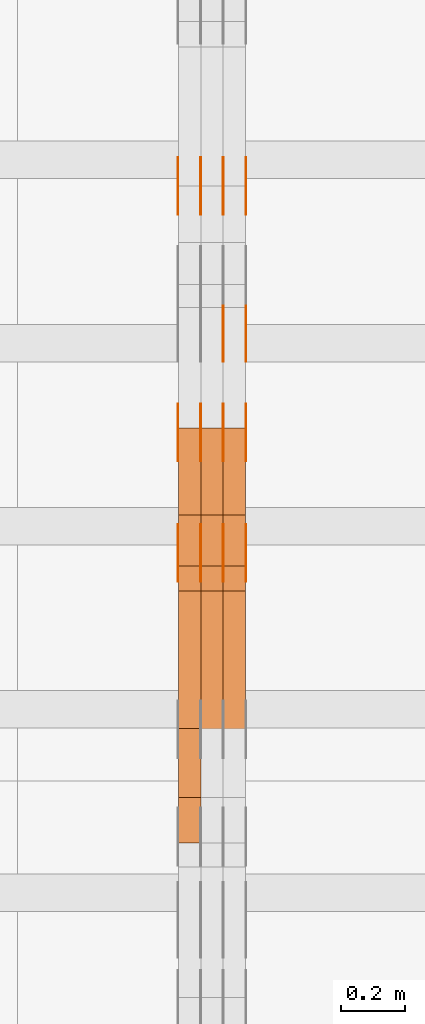
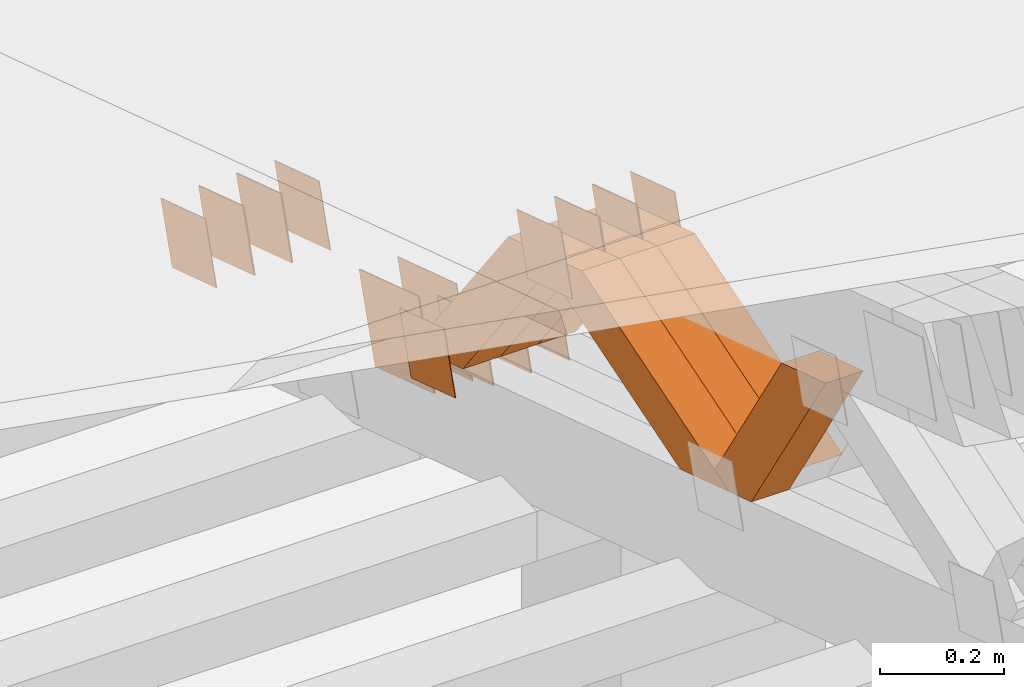
# One storey, part 333 of 385: 28 proxies.
"""IFC2X3 building model written with IfcOpenShell, lengths in millimetres."""

from ifc_helpers import new_model, entity, si_unit, converted_unit, derived_unit, direction, frame, origin, place, context, subcontext, project, spatial, polyline, outline, extrude, source, transform, mapped, material, type_object, type_shapes, element, save


model = new_model("IFC2X3")

# Units and contexts
model_context = context("Model", 3, precision=0.01, world=origin(), true_north=direction((6.12303176911189e-17, 1.0)))
body_context = subcontext(model_context, "Body", "Model", "MODEL_VIEW")
ifc_project = project(units=[si_unit("LENGTHUNIT", "METRE", prefix="MILLI"), si_unit("AREAUNIT", "SQUARE_METRE"), si_unit("VOLUMEUNIT", "CUBIC_METRE"), converted_unit("PLANEANGLEUNIT", "DEGREE", entity("IfcRatioMeasure", 0.0174532925199433), si_unit("PLANEANGLEUNIT", "RADIAN"), dimensions=[0, 0, 0, 0, 0, 0, 0]), si_unit("MASSUNIT", "GRAM", prefix="KILO"), derived_unit("MASSDENSITYUNIT", [(si_unit("MASSUNIT", "GRAM", prefix="KILO"), 1), (si_unit("LENGTHUNIT", "METRE"), -3)]), si_unit("TIMEUNIT", "SECOND"), si_unit("FREQUENCYUNIT", "HERTZ"), si_unit("THERMODYNAMICTEMPERATUREUNIT", "DEGREE_CELSIUS"), derived_unit("THERMALTRANSMITTANCEUNIT", [(si_unit("MASSUNIT", "GRAM", prefix="KILO"), 1), (si_unit("THERMODYNAMICTEMPERATUREUNIT", "KELVIN"), -1), (si_unit("TIMEUNIT", "SECOND"), -3)]), derived_unit("VOLUMETRICFLOWRATEUNIT", [(si_unit("LENGTHUNIT", "METRE"), 3), (si_unit("TIMEUNIT", "SECOND"), -1)]), si_unit("ELECTRICCURRENTUNIT", "AMPERE"), si_unit("ELECTRICVOLTAGEUNIT", "VOLT"), si_unit("POWERUNIT", "WATT"), si_unit("FORCEUNIT", "NEWTON", prefix="KILO"), si_unit("ILLUMINANCEUNIT", "LUX"), si_unit("LUMINOUSFLUXUNIT", "LUMEN"), si_unit("LUMINOUSINTENSITYUNIT", "CANDELA"), derived_unit("USERDEFINED", [(si_unit("MASSUNIT", "GRAM", prefix="KILO"), -1), (si_unit("LENGTHUNIT", "METRE"), -2), (si_unit("TIMEUNIT", "SECOND"), 3), (si_unit("LUMINOUSFLUXUNIT", "LUMEN"), 1)]), derived_unit("LINEARVELOCITYUNIT", [(si_unit("LENGTHUNIT", "METRE"), 1), (si_unit("TIMEUNIT", "SECOND"), -1)]), si_unit("PRESSUREUNIT", "PASCAL"), derived_unit("USERDEFINED", [(si_unit("LENGTHUNIT", "METRE"), -2), (si_unit("MASSUNIT", "GRAM", prefix="KILO"), 1), (si_unit("TIMEUNIT", "SECOND"), -2)])], contexts=[model_context])

# Site, building, storey
site_placement = place(None, origin())
site = spatial("IfcSite", under=ifc_project, at=site_placement, CompositionType="ELEMENT")
building_placement = place(site_placement, origin())
building = spatial("IfcBuilding", under=site, at=building_placement, CompositionType="ELEMENT")
storey_placement = place(building_placement, origin())
storey = spatial("IfcBuildingStorey", under=building, at=storey_placement, Name="Default", CompositionType="ELEMENT", Elevation=0.0)

# Proxies
ifc_material_1 = material(Name="IfcSurfaceStyle #412996")
building_element_proxy_type_1 = type_object("IfcBuildingElementProxyType", PredefinedType="NOTDEFINED", material=ifc_material_1)
shared_shape_1 = source(origin(), body_context, "Body", "SweptSolid", [
    extrude(outline(polyline([(-74.9998794200123, -59.999984515643), (74.9998565677174, -59.999984515643), (74.9998794200123, 59.999984515643), (-74.9998565677174, 59.999984515643), (-74.9998794200123, -59.999984515643)])), frame((75.0000769557496, 60.0000596852268, 0.0), z_axis=(0.0, 0.0, 1.0), x_axis=(-1.0, 0.0, 0.0)), (0.0, 0.0, 1.0), 1.3),
])
type_shapes(building_element_proxy_type_1, [shared_shape_1])
proxy_1_placement = place(building_placement, frame((33386.3, 22649.3668870864, 1282.62115477841), z_axis=(-1.0, 0.0, 0.0), x_axis=(0.0, -0.951056516295124, 0.309016994375039)))
element("IfcBuildingElementProxy", 1, at=proxy_1_placement, inside=storey, type_object=building_element_proxy_type_1, material=ifc_material_1, context=body_context, shape_type="MappedRepresentation", body=[
    mapped(shared_shape_1, transform((0.0, 0.0, 0.0), scale=1.0)),
])
ifc_material_2 = material(Name="IfcSurfaceStyle #412939")
building_element_proxy_type_2 = type_object("IfcBuildingElementProxyType", PredefinedType="NOTDEFINED", material=ifc_material_2)
shared_shape_2 = source(origin(), body_context, "Body", "SweptSolid", [
    extrude(outline(polyline([(-74.9998794200123, -59.999984515643), (74.9998565677174, -59.999984515643), (74.9998794200123, 59.999984515643), (-74.9998565677174, 59.999984515643), (-74.9998794200123, -59.999984515643)])), frame((75.0000769557496, 60.0000596852268, 0.0), z_axis=(0.0, 0.0, 1.0), x_axis=(-1.0, 0.0, 0.0)), (0.0, 0.0, 1.0), 1.3),
])
type_shapes(building_element_proxy_type_2, [shared_shape_2])
proxy_2_placement = place(building_placement, frame((33315.0, 22649.3668870864, 1282.62115477841), z_axis=(-1.0, 0.0, 0.0), x_axis=(0.0, -0.951056516295124, 0.309016994375039)))
element("IfcBuildingElementProxy", 2, at=proxy_2_placement, inside=storey, type_object=building_element_proxy_type_2, material=ifc_material_2, context=body_context, shape_type="MappedRepresentation", body=[
    mapped(shared_shape_2, transform((0.0, 0.0, 0.0), scale=1.0)),
])
ifc_material_3 = material(Name="IfcSurfaceStyle #412882")
building_element_proxy_type_3 = type_object("IfcBuildingElementProxyType", PredefinedType="NOTDEFINED", material=ifc_material_3)
shared_shape_3 = source(origin(), body_context, "Body", "SweptSolid", [
    extrude(outline(polyline([(-74.9998794200123, -59.999984515643), (74.9998565677174, -59.999984515643), (74.9998794200123, 59.999984515643), (-74.9998565677174, 59.999984515643), (-74.9998794200123, -59.999984515643)])), frame((75.0000769557496, 60.0000596852268, 0.0), z_axis=(0.0, 0.0, 1.0), x_axis=(-1.0, 0.0, 0.0)), (0.0, 0.0, 1.0), 1.3),
])
type_shapes(building_element_proxy_type_3, [shared_shape_3])
proxy_3_placement = place(building_placement, frame((33316.3, 22649.3668870864, 1282.62115477841), z_axis=(-1.0, 0.0, 0.0), x_axis=(0.0, -0.951056516295124, 0.309016994375039)))
element("IfcBuildingElementProxy", 3, at=proxy_3_placement, inside=storey, type_object=building_element_proxy_type_3, material=ifc_material_3, context=body_context, shape_type="MappedRepresentation", body=[
    mapped(shared_shape_3, transform((0.0, 0.0, 0.0), scale=1.0)),
])
ifc_material_4 = material(Name="IfcSurfaceStyle #412825")
building_element_proxy_type_4 = type_object("IfcBuildingElementProxyType", PredefinedType="NOTDEFINED", material=ifc_material_4)
shared_shape_4 = source(origin(), body_context, "Body", "SweptSolid", [
    extrude(outline(polyline([(-74.9998794200123, -59.999984515643), (74.9998565677174, -59.999984515643), (74.9998794200123, 59.999984515643), (-74.9998565677174, 59.999984515643), (-74.9998794200123, -59.999984515643)])), frame((75.0000769557496, 60.0000596852268, 0.0), z_axis=(0.0, 0.0, 1.0), x_axis=(-1.0, 0.0, 0.0)), (0.0, 0.0, 1.0), 1.29999999999999),
])
type_shapes(building_element_proxy_type_4, [shared_shape_4])
proxy_4_placement = place(building_placement, frame((33245.0, 22649.3668870864, 1282.62115477841), z_axis=(-1.0, 0.0, 0.0), x_axis=(0.0, -0.951056516295124, 0.309016994375039)))
element("IfcBuildingElementProxy", 4, at=proxy_4_placement, inside=storey, type_object=building_element_proxy_type_4, material=ifc_material_4, context=body_context, shape_type="MappedRepresentation", body=[
    mapped(shared_shape_4, transform((0.0, 0.0, 0.0), scale=1.0)),
])
ifc_material_5 = material(Name="IfcSurfaceStyle #412768")
building_element_proxy_type_5 = type_object("IfcBuildingElementProxyType", PredefinedType="NOTDEFINED", material=ifc_material_5)
shared_shape_5 = source(origin(), body_context, "Body", "SweptSolid", [
    extrude(outline(polyline([(-74.9998794200123, -59.999984515643), (74.9998565677174, -59.999984515643), (74.9998794200123, 59.999984515643), (-74.9998565677174, 59.999984515643), (-74.9998794200123, -59.999984515643)])), frame((75.0000769557496, 60.0000596852268, 0.0), z_axis=(0.0, 0.0, 1.0), x_axis=(-1.0, 0.0, 0.0)), (0.0, 0.0, 1.0), 1.29999999999999),
])
type_shapes(building_element_proxy_type_5, [shared_shape_5])
proxy_5_placement = place(building_placement, frame((33246.3, 22649.3668870864, 1282.62115477841), z_axis=(-1.0, 0.0, 0.0), x_axis=(0.0, -0.951056516295124, 0.309016994375039)))
element("IfcBuildingElementProxy", 5, at=proxy_5_placement, inside=storey, type_object=building_element_proxy_type_5, material=ifc_material_5, context=body_context, shape_type="MappedRepresentation", body=[
    mapped(shared_shape_5, transform((0.0, 0.0, 0.0), scale=1.0)),
])
ifc_material_6 = material(Name="IfcSurfaceStyle #412711")
building_element_proxy_type_6 = type_object("IfcBuildingElementProxyType", PredefinedType="NOTDEFINED", material=ifc_material_6)
shared_shape_6 = source(origin(), body_context, "Body", "SweptSolid", [
    extrude(outline(polyline([(-74.9998794200123, -59.999984515643), (74.9998565677174, -59.999984515643), (74.9998794200123, 59.999984515643), (-74.9998565677174, 59.999984515643), (-74.9998794200123, -59.999984515643)])), frame((75.0000769557496, 60.0000596852268, 0.0), z_axis=(0.0, 0.0, 1.0), x_axis=(-1.0, 0.0, 0.0)), (0.0, 0.0, 1.0), 1.29999999999999),
])
type_shapes(building_element_proxy_type_6, [shared_shape_6])
proxy_6_placement = place(building_placement, frame((33175.0, 22649.3668870864, 1282.62115477841), z_axis=(-1.0, 0.0, 0.0), x_axis=(0.0, -0.951056516295124, 0.309016994375039)))
element("IfcBuildingElementProxy", 6, at=proxy_6_placement, inside=storey, type_object=building_element_proxy_type_6, material=ifc_material_6, context=body_context, shape_type="MappedRepresentation", body=[
    mapped(shared_shape_6, transform((0.0, 0.0, 0.0), scale=1.0)),
])
ifc_material_7 = material(Name="IfcSurfaceStyle #412312")
building_element_proxy_type_7 = type_object("IfcBuildingElementProxyType", PredefinedType="NOTDEFINED", material=ifc_material_7)
shared_shape_7 = source(origin(), body_context, "Body", "SweptSolid", [
    extrude(outline(polyline([(-99.9999579276585, -84.0000593595837), (100.000141865112, -84.0000593595837), (99.9999579276589, 84.0000593595837), (-100.000141865112, 84.0000593595837), (-99.9999579276585, -84.0000593595837)])), frame((100.000141865112, 84.0000593595837, 0.0), z_axis=(0.0, 0.0, 1.0), x_axis=(-1.0, 0.0, 0.0)), (0.0, 0.0, 1.0), 1.3),
])
type_shapes(building_element_proxy_type_7, [shared_shape_7])
proxy_7_placement = place(building_placement, frame((33386.3, 22239.7296395088, 1287.96775368191), z_axis=(-1.0, 0.0, 0.0), x_axis=(0.0, -0.951056516295124, 0.309016994375039)))
element("IfcBuildingElementProxy", 7, at=proxy_7_placement, inside=storey, type_object=building_element_proxy_type_7, material=ifc_material_7, context=body_context, shape_type="MappedRepresentation", body=[
    mapped(shared_shape_7, transform((0.0, 0.0, 0.0), scale=1.0)),
])
ifc_material_8 = material(Name="IfcSurfaceStyle #412255")
building_element_proxy_type_8 = type_object("IfcBuildingElementProxyType", PredefinedType="NOTDEFINED", material=ifc_material_8)
shared_shape_8 = source(origin(), body_context, "Body", "SweptSolid", [
    extrude(outline(polyline([(-99.9999579276585, -84.0000593595837), (100.000141865112, -84.0000593595837), (99.9999579276589, 84.0000593595837), (-100.000141865112, 84.0000593595837), (-99.9999579276585, -84.0000593595837)])), frame((100.000141865112, 84.0000593595837, 0.0), z_axis=(0.0, 0.0, 1.0), x_axis=(-1.0, 0.0, 0.0)), (0.0, 0.0, 1.0), 1.3),
])
type_shapes(building_element_proxy_type_8, [shared_shape_8])
proxy_8_placement = place(building_placement, frame((33315.0, 22239.7296395088, 1287.96775368191), z_axis=(-1.0, 0.0, 0.0), x_axis=(0.0, -0.951056516295124, 0.309016994375039)))
element("IfcBuildingElementProxy", 8, at=proxy_8_placement, inside=storey, type_object=building_element_proxy_type_8, material=ifc_material_8, context=body_context, shape_type="MappedRepresentation", body=[
    mapped(shared_shape_8, transform((0.0, 0.0, 0.0), scale=1.0)),
])
ifc_material_9 = material(Name="IfcSurfaceStyle #412198")
building_element_proxy_type_9 = type_object("IfcBuildingElementProxyType", PredefinedType="NOTDEFINED", material=ifc_material_9)
shared_shape_9 = source(origin(), body_context, "Body", "SweptSolid", [
    extrude(outline(polyline([(-99.9999579276585, -84.0000593595837), (100.000141865112, -84.0000593595837), (99.9999579276589, 84.0000593595837), (-100.000141865112, 84.0000593595837), (-99.9999579276585, -84.0000593595837)])), frame((100.000141865112, 84.0000593595837, 0.0), z_axis=(0.0, 0.0, 1.0), x_axis=(-1.0, 0.0, 0.0)), (0.0, 0.0, 1.0), 1.3),
])
type_shapes(building_element_proxy_type_9, [shared_shape_9])
proxy_9_placement = place(building_placement, frame((33316.3, 22239.7296395088, 1287.96775368191), z_axis=(-1.0, 0.0, 0.0), x_axis=(0.0, -0.951056516295124, 0.309016994375039)))
element("IfcBuildingElementProxy", 9, at=proxy_9_placement, inside=storey, type_object=building_element_proxy_type_9, material=ifc_material_9, context=body_context, shape_type="MappedRepresentation", body=[
    mapped(shared_shape_9, transform((0.0, 0.0, 0.0), scale=1.0)),
])
ifc_material_10 = material(Name="IfcSurfaceStyle #409918")
building_element_proxy_type_10 = type_object("IfcBuildingElementProxyType", PredefinedType="NOTDEFINED", material=ifc_material_10)
shared_shape_10 = source(origin(), body_context, "Body", "SweptSolid", [
    extrude(outline(polyline([(-75.0001116115454, -60.0000599592451), (75.0000887592496, -60.0000599592451), (75.0001116115454, 60.0000599592451), (-75.0000887592496, 60.0000599592451), (-75.0001116115454, -60.0000599592451)])), frame((75.0001116115454, 60.0000599592451, 0.0), z_axis=(0.0, 0.0, 1.0), x_axis=(-1.0, 0.0, 0.0)), (0.0, 0.0, 1.0), 1.3),
])
type_shapes(building_element_proxy_type_10, [shared_shape_10])
proxy_10_placement = place(building_placement, frame((33386.3, 21881.0815195707, 1532.2522473242), z_axis=(-1.0, 0.0, 0.0), x_axis=(0.0, -0.951056516295124, 0.309016994375039)))
element("IfcBuildingElementProxy", 10, at=proxy_10_placement, inside=storey, type_object=building_element_proxy_type_10, material=ifc_material_10, context=body_context, shape_type="MappedRepresentation", body=[
    mapped(shared_shape_10, transform((0.0, 0.0, 0.0), scale=1.0)),
])
ifc_material_11 = material(Name="IfcSurfaceStyle #409861")
building_element_proxy_type_11 = type_object("IfcBuildingElementProxyType", PredefinedType="NOTDEFINED", material=ifc_material_11)
shared_shape_11 = source(origin(), body_context, "Body", "SweptSolid", [
    extrude(outline(polyline([(-75.0001116115454, -60.0000599592451), (75.0000887592496, -60.0000599592451), (75.0001116115454, 60.0000599592451), (-75.0000887592496, 60.0000599592451), (-75.0001116115454, -60.0000599592451)])), frame((75.0001116115454, 60.0000599592451, 0.0), z_axis=(0.0, 0.0, 1.0), x_axis=(-1.0, 0.0, 0.0)), (0.0, 0.0, 1.0), 1.3),
])
type_shapes(building_element_proxy_type_11, [shared_shape_11])
proxy_11_placement = place(building_placement, frame((33315.0, 21881.0815195707, 1532.2522473242), z_axis=(-1.0, 0.0, 0.0), x_axis=(0.0, -0.951056516295124, 0.309016994375039)))
element("IfcBuildingElementProxy", 11, at=proxy_11_placement, inside=storey, type_object=building_element_proxy_type_11, material=ifc_material_11, context=body_context, shape_type="MappedRepresentation", body=[
    mapped(shared_shape_11, transform((0.0, 0.0, 0.0), scale=1.0)),
])
ifc_material_12 = material(Name="IfcSurfaceStyle #409804")
building_element_proxy_type_12 = type_object("IfcBuildingElementProxyType", PredefinedType="NOTDEFINED", material=ifc_material_12)
shared_shape_12 = source(origin(), body_context, "Body", "SweptSolid", [
    extrude(outline(polyline([(-75.0001116115454, -60.0000599592451), (75.0000887592496, -60.0000599592451), (75.0001116115454, 60.0000599592451), (-75.0000887592496, 60.0000599592451), (-75.0001116115454, -60.0000599592451)])), frame((75.0001116115454, 60.0000599592451, 0.0), z_axis=(0.0, 0.0, 1.0), x_axis=(-1.0, 0.0, 0.0)), (0.0, 0.0, 1.0), 1.3),
])
type_shapes(building_element_proxy_type_12, [shared_shape_12])
proxy_12_placement = place(building_placement, frame((33316.3, 21881.0815195707, 1532.2522473242), z_axis=(-1.0, 0.0, 0.0), x_axis=(0.0, -0.951056516295124, 0.309016994375039)))
element("IfcBuildingElementProxy", 12, at=proxy_12_placement, inside=storey, type_object=building_element_proxy_type_12, material=ifc_material_12, context=body_context, shape_type="MappedRepresentation", body=[
    mapped(shared_shape_12, transform((0.0, 0.0, 0.0), scale=1.0)),
])
ifc_material_13 = material(Name="IfcSurfaceStyle #409747")
building_element_proxy_type_13 = type_object("IfcBuildingElementProxyType", PredefinedType="NOTDEFINED", material=ifc_material_13)
shared_shape_13 = source(origin(), body_context, "Body", "SweptSolid", [
    extrude(outline(polyline([(-75.0001116115454, -60.0000599592451), (75.0000887592496, -60.0000599592451), (75.0001116115454, 60.0000599592451), (-75.0000887592496, 60.0000599592451), (-75.0001116115454, -60.0000599592451)])), frame((75.0001116115454, 60.0000599592451, 0.0), z_axis=(0.0, 0.0, 1.0), x_axis=(-1.0, 0.0, 0.0)), (0.0, 0.0, 1.0), 1.29999999999999),
])
type_shapes(building_element_proxy_type_13, [shared_shape_13])
proxy_13_placement = place(building_placement, frame((33245.0, 21881.0815195707, 1532.2522473242), z_axis=(-1.0, 0.0, 0.0), x_axis=(0.0, -0.951056516295124, 0.309016994375039)))
element("IfcBuildingElementProxy", 13, at=proxy_13_placement, inside=storey, type_object=building_element_proxy_type_13, material=ifc_material_13, context=body_context, shape_type="MappedRepresentation", body=[
    mapped(shared_shape_13, transform((0.0, 0.0, 0.0), scale=1.0)),
])
ifc_material_14 = material(Name="IfcSurfaceStyle #409690")
building_element_proxy_type_14 = type_object("IfcBuildingElementProxyType", PredefinedType="NOTDEFINED", material=ifc_material_14)
shared_shape_14 = source(origin(), body_context, "Body", "SweptSolid", [
    extrude(outline(polyline([(-75.0001116115454, -60.0000599592451), (75.0000887592496, -60.0000599592451), (75.0001116115454, 60.0000599592451), (-75.0000887592496, 60.0000599592451), (-75.0001116115454, -60.0000599592451)])), frame((75.0001116115454, 60.0000599592451, 0.0), z_axis=(0.0, 0.0, 1.0), x_axis=(-1.0, 0.0, 0.0)), (0.0, 0.0, 1.0), 1.29999999999999),
])
type_shapes(building_element_proxy_type_14, [shared_shape_14])
proxy_14_placement = place(building_placement, frame((33246.3, 21881.0815195707, 1532.2522473242), z_axis=(-1.0, 0.0, 0.0), x_axis=(0.0, -0.951056516295124, 0.309016994375039)))
element("IfcBuildingElementProxy", 14, at=proxy_14_placement, inside=storey, type_object=building_element_proxy_type_14, material=ifc_material_14, context=body_context, shape_type="MappedRepresentation", body=[
    mapped(shared_shape_14, transform((0.0, 0.0, 0.0), scale=1.0)),
])
ifc_material_15 = material(Name="IfcSurfaceStyle #409633")
building_element_proxy_type_15 = type_object("IfcBuildingElementProxyType", PredefinedType="NOTDEFINED", material=ifc_material_15)
shared_shape_15 = source(origin(), body_context, "Body", "SweptSolid", [
    extrude(outline(polyline([(-75.0001116115454, -60.0000599592451), (75.0000887592496, -60.0000599592451), (75.0001116115454, 60.0000599592451), (-75.0000887592496, 60.0000599592451), (-75.0001116115454, -60.0000599592451)])), frame((75.0001116115454, 60.0000599592451, 0.0), z_axis=(0.0, 0.0, 1.0), x_axis=(-1.0, 0.0, 0.0)), (0.0, 0.0, 1.0), 1.29999999999999),
])
type_shapes(building_element_proxy_type_15, [shared_shape_15])
proxy_15_placement = place(building_placement, frame((33175.0, 21881.0815195707, 1532.2522473242), z_axis=(-1.0, 0.0, 0.0), x_axis=(0.0, -0.951056516295124, 0.309016994375039)))
element("IfcBuildingElementProxy", 15, at=proxy_15_placement, inside=storey, type_object=building_element_proxy_type_15, material=ifc_material_15, context=body_context, shape_type="MappedRepresentation", body=[
    mapped(shared_shape_15, transform((0.0, 0.0, 0.0), scale=1.0)),
])
ifc_material_16 = material(Name="IfcSurfaceStyle #404446")
building_element_proxy_type_16 = type_object("IfcBuildingElementProxyType", PredefinedType="NOTDEFINED", material=ifc_material_16)
shared_shape_16 = source(origin(), body_context, "Body", "SweptSolid", [
    extrude(outline(polyline([(-74.9998794200064, -59.9999845156358), (74.9998565677224, -59.9999845156358), (74.9998794200064, 59.9999845156358), (-74.9998565677224, 59.9999845156358), (-74.9998794200064, -59.9999845156358)])), frame((74.9999765995044, 60.0000596852337, 0.0), z_axis=(0.0, 0.0, 1.0), x_axis=(-1.0, 0.0, 0.0)), (0.0, 0.0, 1.0), 1.3),
])
type_shapes(building_element_proxy_type_16, [shared_shape_16])
proxy_16_placement = place(building_placement, frame((33386.3, 21505.9776314857, 1954.5332951652), z_axis=(-1.0, 0.0, 0.0), x_axis=(0.0, -0.951056516295154, 0.309016994374948)))
element("IfcBuildingElementProxy", 16, at=proxy_16_placement, inside=storey, type_object=building_element_proxy_type_16, material=ifc_material_16, context=body_context, shape_type="MappedRepresentation", body=[
    mapped(shared_shape_16, transform((0.0, 0.0, 0.0), scale=1.0)),
])
ifc_material_17 = material(Name="IfcSurfaceStyle #404389")
building_element_proxy_type_17 = type_object("IfcBuildingElementProxyType", PredefinedType="NOTDEFINED", material=ifc_material_17)
shared_shape_17 = source(origin(), body_context, "Body", "SweptSolid", [
    extrude(outline(polyline([(-74.9998794200064, -59.9999845156358), (74.9998565677224, -59.9999845156358), (74.9998794200064, 59.9999845156358), (-74.9998565677224, 59.9999845156358), (-74.9998794200064, -59.9999845156358)])), frame((74.9999765995044, 60.0000596852337, 0.0), z_axis=(0.0, 0.0, 1.0), x_axis=(-1.0, 0.0, 0.0)), (0.0, 0.0, 1.0), 1.3),
])
type_shapes(building_element_proxy_type_17, [shared_shape_17])
proxy_17_placement = place(building_placement, frame((33315.0, 21505.9776314857, 1954.5332951652), z_axis=(-1.0, 0.0, 0.0), x_axis=(0.0, -0.951056516295154, 0.309016994374948)))
element("IfcBuildingElementProxy", 17, at=proxy_17_placement, inside=storey, type_object=building_element_proxy_type_17, material=ifc_material_17, context=body_context, shape_type="MappedRepresentation", body=[
    mapped(shared_shape_17, transform((0.0, 0.0, 0.0), scale=1.0)),
])
ifc_material_18 = material(Name="IfcSurfaceStyle #404332")
building_element_proxy_type_18 = type_object("IfcBuildingElementProxyType", PredefinedType="NOTDEFINED", material=ifc_material_18)
shared_shape_18 = source(origin(), body_context, "Body", "SweptSolid", [
    extrude(outline(polyline([(-74.9998794200064, -59.9999845156358), (74.9998565677224, -59.9999845156358), (74.9998794200064, 59.9999845156358), (-74.9998565677224, 59.9999845156358), (-74.9998794200064, -59.9999845156358)])), frame((74.9999765995044, 60.0000596852337, 0.0), z_axis=(0.0, 0.0, 1.0), x_axis=(-1.0, 0.0, 0.0)), (0.0, 0.0, 1.0), 1.3),
])
type_shapes(building_element_proxy_type_18, [shared_shape_18])
proxy_18_placement = place(building_placement, frame((33316.3, 21505.9776314857, 1954.5332951652), z_axis=(-1.0, 0.0, 0.0), x_axis=(0.0, -0.951056516295154, 0.309016994374948)))
element("IfcBuildingElementProxy", 18, at=proxy_18_placement, inside=storey, type_object=building_element_proxy_type_18, material=ifc_material_18, context=body_context, shape_type="MappedRepresentation", body=[
    mapped(shared_shape_18, transform((0.0, 0.0, 0.0), scale=1.0)),
])
ifc_material_19 = material(Name="IfcSurfaceStyle #404275")
building_element_proxy_type_19 = type_object("IfcBuildingElementProxyType", PredefinedType="NOTDEFINED", material=ifc_material_19)
shared_shape_19 = source(origin(), body_context, "Body", "SweptSolid", [
    extrude(outline(polyline([(-74.9998794200064, -59.9999845156358), (74.9998565677224, -59.9999845156358), (74.9998794200064, 59.9999845156358), (-74.9998565677224, 59.9999845156358), (-74.9998794200064, -59.9999845156358)])), frame((74.9999765995044, 60.0000596852337, 0.0), z_axis=(0.0, 0.0, 1.0), x_axis=(-1.0, 0.0, 0.0)), (0.0, 0.0, 1.0), 1.29999999999999),
])
type_shapes(building_element_proxy_type_19, [shared_shape_19])
proxy_19_placement = place(building_placement, frame((33245.0, 21505.9776314857, 1954.5332951652), z_axis=(-1.0, 0.0, 0.0), x_axis=(0.0, -0.951056516295154, 0.309016994374948)))
element("IfcBuildingElementProxy", 19, at=proxy_19_placement, inside=storey, type_object=building_element_proxy_type_19, material=ifc_material_19, context=body_context, shape_type="MappedRepresentation", body=[
    mapped(shared_shape_19, transform((0.0, 0.0, 0.0), scale=1.0)),
])
ifc_material_20 = material(Name="IfcSurfaceStyle #404218")
building_element_proxy_type_20 = type_object("IfcBuildingElementProxyType", PredefinedType="NOTDEFINED", material=ifc_material_20)
shared_shape_20 = source(origin(), body_context, "Body", "SweptSolid", [
    extrude(outline(polyline([(-74.9998794200064, -59.9999845156358), (74.9998565677224, -59.9999845156358), (74.9998794200064, 59.9999845156358), (-74.9998565677224, 59.9999845156358), (-74.9998794200064, -59.9999845156358)])), frame((74.9999765995044, 60.0000596852337, 0.0), z_axis=(0.0, 0.0, 1.0), x_axis=(-1.0, 0.0, 0.0)), (0.0, 0.0, 1.0), 1.29999999999999),
])
type_shapes(building_element_proxy_type_20, [shared_shape_20])
proxy_20_placement = place(building_placement, frame((33246.3, 21505.9776314857, 1954.5332951652), z_axis=(-1.0, 0.0, 0.0), x_axis=(0.0, -0.951056516295154, 0.309016994374948)))
element("IfcBuildingElementProxy", 20, at=proxy_20_placement, inside=storey, type_object=building_element_proxy_type_20, material=ifc_material_20, context=body_context, shape_type="MappedRepresentation", body=[
    mapped(shared_shape_20, transform((0.0, 0.0, 0.0), scale=1.0)),
])
ifc_material_21 = material(Name="IfcSurfaceStyle #404161")
building_element_proxy_type_21 = type_object("IfcBuildingElementProxyType", PredefinedType="NOTDEFINED", material=ifc_material_21)
shared_shape_21 = source(origin(), body_context, "Body", "SweptSolid", [
    extrude(outline(polyline([(-74.9998794200064, -59.9999845156358), (74.9998565677224, -59.9999845156358), (74.9998794200064, 59.9999845156358), (-74.9998565677224, 59.9999845156358), (-74.9998794200064, -59.9999845156358)])), frame((74.9999765995044, 60.0000596852337, 0.0), z_axis=(0.0, 0.0, 1.0), x_axis=(-1.0, 0.0, 0.0)), (0.0, 0.0, 1.0), 1.29999999999999),
])
type_shapes(building_element_proxy_type_21, [shared_shape_21])
proxy_21_placement = place(building_placement, frame((33175.0, 21505.9776314857, 1954.5332951652), z_axis=(-1.0, 0.0, 0.0), x_axis=(0.0, -0.951056516295154, 0.309016994374948)))
element("IfcBuildingElementProxy", 21, at=proxy_21_placement, inside=storey, type_object=building_element_proxy_type_21, material=ifc_material_21, context=body_context, shape_type="MappedRepresentation", body=[
    mapped(shared_shape_21, transform((0.0, 0.0, 0.0), scale=1.0)),
])
ifc_material_22 = material(Name="IfcSurfaceStyle #392470")
building_element_proxy_type_22 = type_object("IfcBuildingElementProxyType", Name="T1-W29 392468", PredefinedType="NOTDEFINED", material=ifc_material_22)
shared_shape_22 = source(origin(), body_context, "Body", "SweptSolid", [
    extrude(outline(polyline([(-202.325994317059, -47.5000867467013), (200.714255560873, -47.5000867467013), (187.834128885383, 0.000593513395139059), (130.590899902046, 47.4997899900038), (-316.813290031243, 47.4997899900038), (-202.325994317059, -47.5000867467013)])), frame((200.714255560873, 47.5001935424745, 0.0), z_axis=(0.0, 0.0, 1.0), x_axis=(-1.0, 0.0, 0.0)), (0.0, 0.0, 1.0), 70.0),
])
type_shapes(building_element_proxy_type_22, [shared_shape_22])
proxy_22_placement = place(building_placement, frame((33245.0, 20827.0771193222, 1890.72342063252), z_axis=(-1.0, 0.0, 0.0), x_axis=(0.0, -0.534567451138397, 0.845125813227473)))
element("IfcBuildingElementProxy", 22, at=proxy_22_placement, inside=storey, type_object=building_element_proxy_type_22, material=ifc_material_22, Name="T1-W29", context=body_context, shape_type="MappedRepresentation", body=[
    mapped(shared_shape_22, transform((0.0, 0.0, 0.0), scale=1.0)),
])
ifc_material_23 = material(Name="IfcSurfaceStyle #392206")
building_element_proxy_type_23 = type_object("IfcBuildingElementProxyType", Name="T1-W20 392204", PredefinedType="NOTDEFINED", material=ifc_material_23)
shared_shape_23 = source(origin(), body_context, "Body", "SweptSolid", [
    extrude(outline(polyline([(-355.264945969921, -47.5000317999193), (141.064821099313, -47.5000317999193), (208.541978467889, 8.19311626391928e-05), (225.96877763549, 47.499990834338), (-220.31063123277, 47.4999908343379), (-355.264945969921, -47.5000317999193)])), frame((225.968921063481, 47.5000683592689, 0.0), z_axis=(0.0, 0.0, 1.0), x_axis=(-1.0, 0.0, 0.0)), (0.0, 0.0, 1.0), 70.0),
])
type_shapes(building_element_proxy_type_23, [shared_shape_23])
proxy_23_placement = place(building_placement, frame((33385.0, 21443.7472302196, 2007.54830804072), z_axis=(-1.0, 0.0, 0.0), x_axis=(0.0, -0.95556995517236, -0.29476441571515)))
element("IfcBuildingElementProxy", 23, at=proxy_23_placement, inside=storey, type_object=building_element_proxy_type_23, material=ifc_material_23, Name="T1-W20", context=body_context, shape_type="MappedRepresentation", body=[
    mapped(shared_shape_23, transform((0.0, 0.0, 0.0), scale=1.0)),
])
ifc_material_24 = material(Name="IfcSurfaceStyle #392140")
building_element_proxy_type_24 = type_object("IfcBuildingElementProxyType", Name="T1-W20 392138", PredefinedType="NOTDEFINED", material=ifc_material_24)
shared_shape_24 = source(origin(), body_context, "Body", "SweptSolid", [
    extrude(outline(polyline([(-355.264945969921, -47.5000317999193), (141.064821099313, -47.5000317999193), (208.541978467889, 8.19311626391928e-05), (225.96877763549, 47.499990834338), (-220.31063123277, 47.4999908343379), (-355.264945969921, -47.5000317999193)])), frame((225.968921063481, 47.5000683592689, 0.0), z_axis=(0.0, 0.0, 1.0), x_axis=(-1.0, 0.0, 0.0)), (0.0, 0.0, 1.0), 70.0),
])
type_shapes(building_element_proxy_type_24, [shared_shape_24])
proxy_24_placement = place(building_placement, frame((33315.0, 21443.7472302196, 2007.54830804072), z_axis=(-1.0, 0.0, 0.0), x_axis=(0.0, -0.95556995517236, -0.29476441571515)))
element("IfcBuildingElementProxy", 24, at=proxy_24_placement, inside=storey, type_object=building_element_proxy_type_24, material=ifc_material_24, Name="T1-W20", context=body_context, shape_type="MappedRepresentation", body=[
    mapped(shared_shape_24, transform((0.0, 0.0, 0.0), scale=1.0)),
])
ifc_material_25 = material(Name="IfcSurfaceStyle #392074")
building_element_proxy_type_25 = type_object("IfcBuildingElementProxyType", Name="T1-W20 392072", PredefinedType="NOTDEFINED", material=ifc_material_25)
shared_shape_25 = source(origin(), body_context, "Body", "SweptSolid", [
    extrude(outline(polyline([(-355.264945969921, -47.5000317999193), (141.064821099313, -47.5000317999193), (208.541978467889, 8.19311626391928e-05), (225.96877763549, 47.499990834338), (-220.31063123277, 47.4999908343379), (-355.264945969921, -47.5000317999193)])), frame((225.968921063481, 47.5000683592689, 0.0), z_axis=(0.0, 0.0, 1.0), x_axis=(-1.0, 0.0, 0.0)), (0.0, 0.0, 1.0), 70.0),
])
type_shapes(building_element_proxy_type_25, [shared_shape_25])
proxy_25_placement = place(building_placement, frame((33245.0, 21443.7472302196, 2007.54830804072), z_axis=(-1.0, 0.0, 0.0), x_axis=(0.0, -0.95556995517236, -0.29476441571515)))
element("IfcBuildingElementProxy", 25, at=proxy_25_placement, inside=storey, type_object=building_element_proxy_type_25, material=ifc_material_25, Name="T1-W20", context=body_context, shape_type="MappedRepresentation", body=[
    mapped(shared_shape_25, transform((0.0, 0.0, 0.0), scale=1.0)),
])
ifc_material_26 = material(Name="IfcSurfaceStyle #391810")
building_element_proxy_type_26 = type_object("IfcBuildingElementProxyType", Name="T1-W18 391808", PredefinedType="NOTDEFINED", material=ifc_material_26)
shared_shape_26 = source(origin(), body_context, "Body", "SweptSolid", [
    extrude(outline(polyline([(-221.504996322134, -47.4999929258616), (225.406467948779, -47.4999929258616), (211.663832468686, -0.000107703153482008), (143.08905281687, 47.5000467774384), (-358.6543569122, 47.5000467774384), (-221.504996322134, -47.4999929258616)])), frame((225.406576158364, 47.5000467774384, 0.0), z_axis=(0.0, 0.0, 1.0), x_axis=(-1.0, 0.0, 0.0)), (0.0, 0.0, 1.0), 70.0),
])
type_shapes(building_element_proxy_type_26, [shared_shape_26])
proxy_26_placement = place(building_placement, frame((33385.0, 21766.9513837803, 1583.13813361817), z_axis=(-1.0, 0.0, 0.0), x_axis=(0.0, -0.605858491298265, 0.795572428206126)))
element("IfcBuildingElementProxy", 26, at=proxy_26_placement, inside=storey, type_object=building_element_proxy_type_26, material=ifc_material_26, Name="T1-W18", context=body_context, shape_type="MappedRepresentation", body=[
    mapped(shared_shape_26, transform((0.0, 0.0, 0.0), scale=1.0)),
])
ifc_material_27 = material(Name="IfcSurfaceStyle #391744")
building_element_proxy_type_27 = type_object("IfcBuildingElementProxyType", Name="T1-W18 391742", PredefinedType="NOTDEFINED", material=ifc_material_27)
shared_shape_27 = source(origin(), body_context, "Body", "SweptSolid", [
    extrude(outline(polyline([(-221.504996322134, -47.4999929258616), (225.406467948779, -47.4999929258616), (211.663832468686, -0.000107703153482008), (143.08905281687, 47.5000467774384), (-358.6543569122, 47.5000467774384), (-221.504996322134, -47.4999929258616)])), frame((225.406576158364, 47.5000467774384, 0.0), z_axis=(0.0, 0.0, 1.0), x_axis=(-1.0, 0.0, 0.0)), (0.0, 0.0, 1.0), 70.0),
])
type_shapes(building_element_proxy_type_27, [shared_shape_27])
proxy_27_placement = place(building_placement, frame((33315.0, 21766.9513837803, 1583.13813361817), z_axis=(-1.0, 0.0, 0.0), x_axis=(0.0, -0.605858491298265, 0.795572428206126)))
element("IfcBuildingElementProxy", 27, at=proxy_27_placement, inside=storey, type_object=building_element_proxy_type_27, material=ifc_material_27, Name="T1-W18", context=body_context, shape_type="MappedRepresentation", body=[
    mapped(shared_shape_27, transform((0.0, 0.0, 0.0), scale=1.0)),
])
ifc_material_28 = material(Name="IfcSurfaceStyle #391678")
building_element_proxy_type_28 = type_object("IfcBuildingElementProxyType", Name="T1-W18 391676", PredefinedType="NOTDEFINED", material=ifc_material_28)
shared_shape_28 = source(origin(), body_context, "Body", "SweptSolid", [
    extrude(outline(polyline([(-221.504996322134, -47.4999929258616), (225.406467948779, -47.4999929258616), (211.663832468686, -0.000107703153482008), (143.08905281687, 47.5000467774384), (-358.6543569122, 47.5000467774384), (-221.504996322134, -47.4999929258616)])), frame((225.406576158364, 47.5000467774384, 0.0), z_axis=(0.0, 0.0, 1.0), x_axis=(-1.0, 0.0, 0.0)), (0.0, 0.0, 1.0), 70.0),
])
type_shapes(building_element_proxy_type_28, [shared_shape_28])
proxy_28_placement = place(building_placement, frame((33245.0, 21766.9513837803, 1583.13813361817), z_axis=(-1.0, 0.0, 0.0), x_axis=(0.0, -0.605858491298265, 0.795572428206126)))
element("IfcBuildingElementProxy", 28, at=proxy_28_placement, inside=storey, type_object=building_element_proxy_type_28, material=ifc_material_28, Name="T1-W18", context=body_context, shape_type="MappedRepresentation", body=[
    mapped(shared_shape_28, transform((0.0, 0.0, 0.0), scale=1.0)),
])

save(model, "model.ifc")
